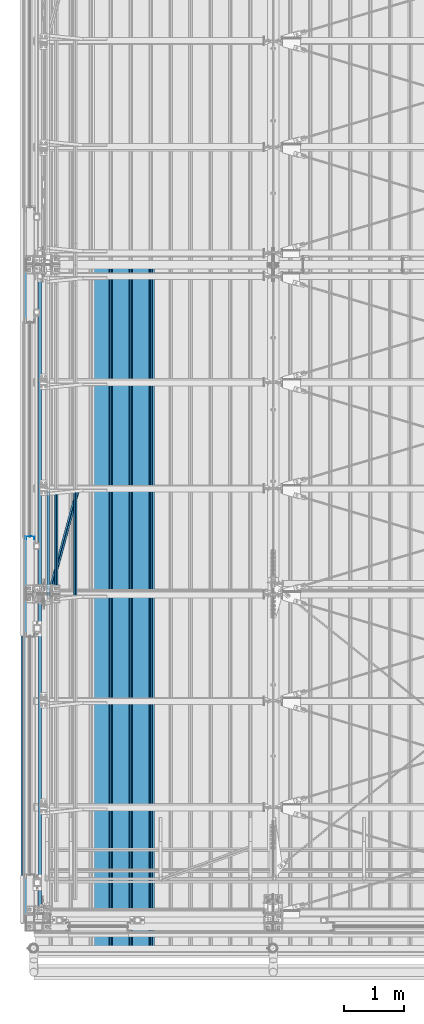
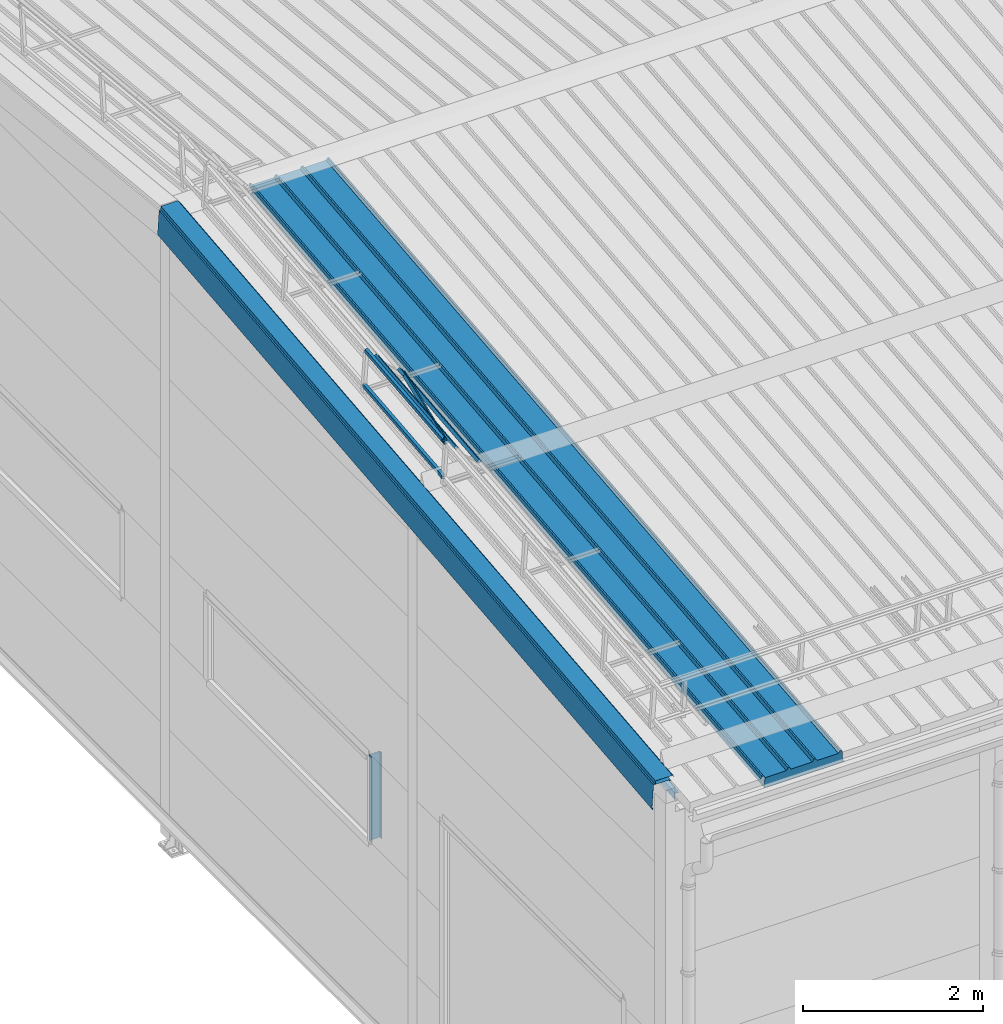
# One storey, part 33 of 709: 10 beams, 10 elements without a shape of their own.
"""IFC4 building model written with IfcOpenShell, lengths in millimetres."""

import ifcopenshell
import ifcopenshell.guid

model = None  # the IFC model being written
_history = None  # IfcOwnerHistory: only IFC2X3 demands one
_inside = {}  # id of a spatial element -> (the spatial element, [elements in it])
_under = {}  # id of a project, library or spatial element -> (it, [spatial elements below it])
_declared = {}  # id of a project -> (the project, [libraries it declares])
_typed = {}  # id of a type object -> (the type object, [elements of that type])
_made_of = {}  # id of a material, layer set ... -> (it, [elements and type objects made of it])


def new_model(schema):
    """Start an empty IFC model of exactly this schema.

    Asked for "IFC4X3", IfcOpenShell would pick the latest addendum, in which some entities
    have other attributes; the version numbers below select the first issue.
    IFC2X3 requires an IfcOwnerHistory on every rooted entity: one is made here for all.
    """
    global model, _history
    if schema == "IFC4X3":
        model = ifcopenshell.file(schema_version=(4, 3, 0, 0))
    else:
        model = ifcopenshell.file(schema=schema)
    _inside.clear()
    _under.clear()
    _declared.clear()
    _typed.clear()
    _made_of.clear()
    _history = None
    if model.schema == "IFC2X3":
        org = make("IfcOrganization", Name="unknown")
        user = make(
            "IfcPersonAndOrganization",
            ThePerson=make("IfcPerson", FamilyName="unknown"),
            TheOrganization=org,
        )
        app = make(
            "IfcApplication",
            ApplicationDeveloper=org,
            Version="unknown",
            ApplicationFullName="unknown",
            ApplicationIdentifier="unknown",
        )
        _history = make(
            "IfcOwnerHistory",
            OwningUser=user,
            OwningApplication=app,
            ChangeAction="ADDED",
            CreationDate=0,
        )
    return model


def make(cls, **values):
    """One entity of the class cls with the attributes given. An attribute that is None is left unset."""
    return model.create_entity(
        cls, **{name: value for name, value in values.items() if value is not None}
    )


def rooted(cls, **values):
    """An entity with a GlobalId (a new one), such as an element, a storey or a relation."""
    return make(cls, GlobalId=ifcopenshell.guid.new(), OwnerHistory=_history, **values)


def si_unit(unit_type, name, prefix=None):
    """IfcSIUnit, for example si_unit("LENGTHUNIT", "METRE", prefix="MILLI")."""
    return make("IfcSIUnit", UnitType=unit_type, Prefix=prefix, Name=name)


def assignment(units):
    """IfcUnitAssignment: the units of a project."""
    return None if units is None else make("IfcUnitAssignment", Units=units)


def point(xyz):
    """IfcCartesianPoint."""
    return None if xyz is None else make("IfcCartesianPoint", Coordinates=xyz)


def direction(xyz):
    """IfcDirection."""
    return None if xyz is None else make("IfcDirection", DirectionRatios=xyz)


def frame(location, z_axis=None, x_axis=None):
    """IfcAxis2Placement3D, a coordinate frame: its origin and axes. An axis left out is left unset."""
    return make(
        "IfcAxis2Placement3D",
        Location=point(location),
        Axis=direction(z_axis),
        RefDirection=direction(x_axis),
    )


def origin_with_axes():
    """The frame at (0, 0, 0) with the z axis (0, 0, 1) and the x axis (1, 0, 0) written out."""
    return frame((0.0, 0.0, 0.0), z_axis=(0.0, 0.0, 1.0), x_axis=(1.0, 0.0, 0.0))


def place(relative_to, where):
    """IfcLocalPlacement: puts the frame where relative to a parent placement (None: the world)."""
    return make(
        "IfcLocalPlacement", PlacementRelTo=relative_to, RelativePlacement=where
    )


def context(
    kind, dimensions, precision=None, world=None, true_north=None, identifier=None
):
    """IfcGeometricRepresentationContext, for example the 3D "Model" context."""
    return make(
        "IfcGeometricRepresentationContext",
        ContextIdentifier=identifier,
        ContextType=kind,
        CoordinateSpaceDimension=dimensions,
        Precision=precision,
        WorldCoordinateSystem=world,
        TrueNorth=true_north,
    )


def subcontext(parent, identifier, kind, view, scale=None):
    """IfcGeometricRepresentationSubContext, for example "Body" below "Model"."""
    return make(
        "IfcGeometricRepresentationSubContext",
        ContextIdentifier=identifier,
        ContextType=kind,
        ParentContext=parent,
        TargetScale=scale,
        TargetView=view,
    )


def project(units=None, contexts=None):
    """IfcProject with its units and contexts."""
    return rooted(
        "IfcProject",
        Name="project",
        RepresentationContexts=contexts,
        UnitsInContext=assignment(units),
    )


def spatial(cls, under=None, at=None, **own):
    """A site, building, storey or space (cls), placed at a placement, below another one or the project."""
    s = rooted(cls, ObjectPlacement=at, **own)
    if under is not None:
        _under.setdefault(under.id(), (under, []))[1].append(s)
    return s


def point_list(points):
    """IfcCartesianPointList2D or 3D."""
    cls = (
        "IfcCartesianPointList2D" if len(points[0]) == 2 else "IfcCartesianPointList3D"
    )
    return make(cls, CoordList=points)


def line(*indices):
    """IfcLineIndex: a straight run through numbered points of an indexed curve."""
    return model.create_entity("IfcLineIndex", indices)


def indexed_curve(points, segments=None, self_intersect=None):
    """IfcIndexedPolyCurve: lines and arcs through numbered points (the first is 1)."""
    return make(
        "IfcIndexedPolyCurve",
        Points=point_list(points),
        Segments=segments,
        SelfIntersect=self_intersect,
    )


def outline(outer, holes=None, kind="AREA"):
    """IfcArbitraryClosedProfileDef: a profile drawn as a closed curve; with holes, ...WithVoids."""
    if holes is None:
        return make("IfcArbitraryClosedProfileDef", ProfileType=kind, OuterCurve=outer)
    return make(
        "IfcArbitraryProfileDefWithVoids",
        ProfileType=kind,
        OuterCurve=outer,
        InnerCurves=holes,
    )


def extrude(swept, where, along, depth):
    """IfcExtrudedAreaSolid: the profile swept, set in the frame where, extruded along a direction by depth."""
    return make(
        "IfcExtrudedAreaSolid",
        SweptArea=swept,
        Position=where,
        ExtrudedDirection=direction(along),
        Depth=depth,
    )


def shape(context_of_items, identifier, shape_type, items):
    """IfcShapeRepresentation: the items that make up one representation, for example the "Body"."""
    return make(
        "IfcShapeRepresentation",
        ContextOfItems=context_of_items,
        RepresentationIdentifier=identifier,
        RepresentationType=shape_type,
        Items=items,
    )


def material(Name=None, Category=None):
    """IfcMaterial."""
    return make("IfcMaterial", Name=Name, Category=Category)


def made_of(thing, what):
    """Note that an element or type object is made of a material, layer set ...; save() writes the relation."""
    if what is not None:
        _made_of.setdefault(what.id(), (what, []))[1].append(thing)
    return thing


def element(
    cls,
    number,
    at=None,
    inside=None,
    cuts=None,
    type_object=None,
    material=None,
    context=None,
    identifier="Body",
    shape_type=None,
    held_by="IfcProductDefinitionShape",
    body=None,
    shapes=None,
    **own,
):
    """One element of the class cls, such as IfcWall. Its Tag is "e" and its number.

    at: its placement. inside: the storey or other place that contains it. cuts: it is an
    opening in that element (IfcRelVoidsElement). A single representation is given by context,
    identifier, shape_type and body (its items); several are given by shapes. held_by: the class
    of the entity that holds the representations. save() writes the other relations.
    """
    e = rooted(cls, Tag="e%d" % number, ObjectPlacement=at, **own)
    if body is not None:
        shapes = [shape(context, identifier, shape_type, body)]
    if shapes is not None:
        e.Representation = make(held_by, Representations=shapes)
    if inside is not None:
        _inside.setdefault(inside.id(), (inside, []))[1].append(e)
    if cuts is not None:
        rooted(
            "IfcRelVoidsElement", RelatingBuildingElement=cuts, RelatedOpeningElement=e
        )
    if type_object is not None:
        _typed.setdefault(type_object.id(), (type_object, []))[1].append(e)
    return made_of(e, material)


def aggregate(whole, parts):
    """IfcRelAggregates: a whole, such as a stair, and the parts it consists of."""
    return rooted("IfcRelAggregates", RelatingObject=whole, RelatedObjects=parts)


def save(model, path):
    """Write the relations noted so far, then the file.

    IfcRelAggregates (storeys below a building ...), IfcRelContainedInSpatialStructure (elements
    in a storey), IfcRelDefinesByType, IfcRelAssociatesMaterial and IfcRelDeclares: one each for
    every whole, place, type object, material and project.
    """
    for whole, parts in _under.values():
        aggregate(whole, parts)
    for where, things in _inside.values():
        rooted(
            "IfcRelContainedInSpatialStructure",
            RelatedElements=things,
            RelatingStructure=where,
        )
    for kind, things in _typed.values():
        rooted("IfcRelDefinesByType", RelatedObjects=things, RelatingType=kind)
    for what, things in _made_of.values():
        rooted("IfcRelAssociatesMaterial", RelatedObjects=things, RelatingMaterial=what)
    for by, libraries in _declared.values():
        rooted("IfcRelDeclares", RelatingContext=by, RelatedDefinitions=libraries)
    model.write(path)


model = new_model("IFC4")

# Units and contexts
model_context = context("Model", 3, precision=0.2, world=origin_with_axes(), true_north=direction((0.0, 1.0)))
body_context = subcontext(model_context, "Body", "Model", "MODEL_VIEW")
ifc_project = project(units=[si_unit("LENGTHUNIT", "METRE", prefix="MILLI"), si_unit("AREAUNIT", "SQUARE_METRE"), si_unit("VOLUMEUNIT", "CUBIC_METRE"), si_unit("MASSUNIT", "GRAM", prefix="KILO"), si_unit("TIMEUNIT", "SECOND"), si_unit("PLANEANGLEUNIT", "RADIAN"), si_unit("SOLIDANGLEUNIT", "STERADIAN"), si_unit("THERMODYNAMICTEMPERATUREUNIT", "DEGREE_CELSIUS"), si_unit("LUMINOUSINTENSITYUNIT", "LUMEN")], contexts=[model_context])

# Site, building, storey
site_placement = place(None, origin_with_axes())
site = spatial("IfcSite", under=ifc_project, at=site_placement, CompositionType="ELEMENT")
building_placement = place(site_placement, origin_with_axes())
building = spatial("IfcBuilding", under=site, at=building_placement, Name="Undefined", CompositionType="ELEMENT")
storey_placement = place(building_placement, origin_with_axes())
storey = spatial("IfcBuildingStorey", under=building, at=storey_placement, Name="Undefined", CompositionType="ELEMENT", Elevation=0.0)

# Assembly, beam
assembly_1_placement = place(storey_placement, frame((1452.44, -410.89541, 7279.78979), z_axis=(1.0, 0.0, 0.0), x_axis=(0.0, 0.9950371902, 0.099503719)))
assembly_1 = element("IfcElementAssembly", 1, at=assembly_1_placement, inside=storey)
ifc_material_1 = material(Name="Insulation", Category="Insulation")
beam_1_placement = place(assembly_1_placement, origin_with_axes())
beam_1 = element("IfcBeam", 2, at=beam_1_placement, material=ifc_material_1, ObjectType="P-99", context=body_context, shape_type="SolidModel", body=[
    extrude(outline(indexed_curve([(-509.8453, 89.5), (-490.1547, 89.5), (-471.67949, 57.5), (-471.67949, -88.5), (-436.67949, -88.5), (-436.67949, -91.5), (562.55841, -91.5), (562.55841, -89.5), (527.55841, -89.5), (527.55841, 57.5), (510.2379, 88.5), (489.7621, 88.5), (472.44159, 58.5), (196.71923, 58.5), (177.66667, 91.5), (155.66667, 91.5), (136.61411, 58.5), (-136.61411, 58.5), (-155.66667, 91.5), (-177.66667, 91.5), (-196.71923, 58.5), (-469.94744, 58.5), (-489.0, 91.5), (-511.0, 91.5), (-527.16581, 63.5), (-525.43376, 62.5)], segments=[line(1, 2, 3, 4, 5, 6, 7, 8, 9, 10, 11, 12, 13, 14, 15, 16, 17, 18, 19, 20, 21, 22, 23, 24, 25, 26, 1)])), frame((0.0, 0.0, 0.0), z_axis=(-1.0, 0.0, 0.0), x_axis=(0.0, 0.0, 1.0)), (0.0, 0.0, -1.0), 11459.0),
])
aggregate(assembly_1, [beam_1])

assembly_2_placement = place(storey_placement, frame((240.0, 5395.5211, 8622.71451), z_axis=(1.0, 0.0, 0.0), x_axis=(0.0, 0.9950371902, 0.099503719)))
assembly_2 = element("IfcElementAssembly", 3, at=assembly_2_placement, inside=storey)
ifc_material_2 = material(Name="Steel_Undefined", Category="STEEL")
beam_2_placement = place(assembly_2_placement, origin_with_axes())
beam_2 = element("IfcBeam", 4, at=beam_2_placement, material=ifc_material_2, ObjectType="610", context=body_context, shape_type="SolidModel", body=[
    extrude(outline(indexed_curve([(-20.0, -25.0), (20.0, -25.0), (20.0, -22.5), (-17.5, -22.5), (-17.5, 22.5), (20.0, 22.5), (20.0, 25.0), (-20.0, 25.0)], segments=[line(1, 2, 3, 4, 5, 6, 7, 8, 1)])), frame((0.0, 0.0, 0.0), z_axis=(-1.0, 0.0, 0.0), x_axis=(0.0, 0.0, 1.0)), (0.0, 0.0, -1.0), 1782.14469),
])
aggregate(assembly_2, [beam_2])

assembly_3_placement = place(storey_placement, frame((240.0, 5445.27295, 8125.19591), z_axis=(1.0, 0.0, 0.0), x_axis=(0.0, 0.9950371902, 0.099503719)))
assembly_3 = element("IfcElementAssembly", 5, at=assembly_3_placement, inside=storey)
beam_3_placement = place(assembly_3_placement, origin_with_axes())
beam_3 = element("IfcBeam", 6, at=beam_3_placement, material=ifc_material_2, ObjectType="610", context=body_context, shape_type="SolidModel", body=[
    extrude(outline(indexed_curve([(-20.0, -25.0), (20.0, -25.0), (20.0, -22.5), (-17.5, -22.5), (-17.5, 22.5), (20.0, 22.5), (20.0, 25.0), (-20.0, 25.0)], segments=[line(1, 2, 3, 4, 5, 6, 7, 8, 1)])), frame((0.0, 0.0, 0.0), z_axis=(-1.0, 0.0, 0.0), x_axis=(0.0, 0.0, 1.0)), (0.0, 0.0, -1.0), 1782.14469),
])
aggregate(assembly_3, [beam_3])

assembly_4_placement = place(storey_placement, frame((375.56349, 5408.18585, 8496.06695), z_axis=(0.7071067814, -0.0703597545, 0.7035975445), x_axis=(0.0, 0.9950371902, 0.099503719)))
assembly_4 = element("IfcElementAssembly", 7, at=assembly_4_placement, inside=storey)
beam_4_placement = place(assembly_4_placement, origin_with_axes())
beam_4 = element("IfcBeam", 8, at=beam_4_placement, material=ifc_material_2, ObjectType="610", context=body_context, shape_type="SolidModel", body=[
    extrude(outline(indexed_curve([(-20.0, -25.0), (20.0, -25.0), (20.0, -22.5), (-17.5, -22.5), (-17.5, 22.5), (20.0, 22.5), (20.0, 25.0), (-20.0, 25.0)], segments=[line(1, 2, 3, 4, 5, 6, 7, 8, 1)])), frame((0.0, 0.0, 0.0), z_axis=(-1.0, 0.0, 0.0), x_axis=(0.0, 0.0, 1.0)), (0.0, 0.0, -1.0), 1782.14469),
])
aggregate(assembly_4, [beam_4])

assembly_5_placement = place(storey_placement, frame((692.72078, 5439.74418, 8180.48365), z_axis=(0.7071067814, -0.0703597545, 0.7035975445), x_axis=(0.0, 0.9950371902, 0.099503719)))
assembly_5 = element("IfcElementAssembly", 9, at=assembly_5_placement, inside=storey)
beam_5_placement = place(assembly_5_placement, origin_with_axes())
beam_5 = element("IfcBeam", 10, at=beam_5_placement, material=ifc_material_2, ObjectType="610", context=body_context, shape_type="SolidModel", body=[
    extrude(outline(indexed_curve([(-20.0, -25.0), (20.0, -25.0), (20.0, -22.5), (-17.5, -22.5), (-17.5, 22.5), (20.0, 22.5), (20.0, 25.0), (-20.0, 25.0)], segments=[line(1, 2, 3, 4, 5, 6, 7, 8, 1)])), frame((0.0, 0.0, 0.0), z_axis=(-1.0, 0.0, 0.0), x_axis=(0.0, 0.0, 1.0)), (0.0, 0.0, -1.0), 1782.14469),
])
aggregate(assembly_5, [beam_5])

assembly_6_placement = place(storey_placement, frame((234.14214, 5394.1139, 8636.78646), z_axis=(0.7071067814, -0.0703597545, 0.7035975445), x_axis=(0.2585142339, 0.9518781635, -0.1646157729)))
assembly_6 = element("IfcElementAssembly", 11, at=assembly_6_placement, inside=storey)
beam_6_placement = place(assembly_6_placement, origin_with_axes())
beam_6 = element("IfcBeam", 12, at=beam_6_placement, material=ifc_material_2, ObjectType="612", context=body_context, shape_type="SolidModel", body=[
    extrude(outline(indexed_curve([(-20.0, -25.0), (20.0, -25.0), (20.0, -22.5), (-17.5, -22.5), (-17.5, 22.5), (20.0, 22.5), (20.0, 25.0), (-20.0, 25.0)], segments=[line(1, 2, 3, 4, 5, 6, 7, 8, 1)])), frame((0.0, 0.0, 0.0), z_axis=(-1.0, 0.0, 0.0), x_axis=(0.0, 0.0, 1.0)), (0.0, 0.0, -1.0), 1914.6905),
])
aggregate(assembly_6, [beam_6])

assembly_7_placement = place(storey_placement, frame((-60.0, 6440.0, 3870.0), z_axis=(1.0, 0.0, 0.0), x_axis=(0.0, 0.0, -1.0)))
assembly_7 = element("IfcElementAssembly", 13, at=assembly_7_placement, inside=storey)
beam_7_placement = place(assembly_7_placement, origin_with_axes())
beam_7 = element("IfcBeam", 14, at=beam_7_placement, material=ifc_material_2, context=body_context, shape_type="SolidModel", body=[
    extrude(outline(indexed_curve([(-70.0, -25.0), (-68.0, -25.0), (-68.0, 23.0), (68.0, 23.0), (68.0, -25.0), (70.0, -25.0), (70.0, 25.0), (-70.0, 25.0)], segments=[line(1, 2, 3, 4, 5, 6, 7, 8, 1)])), frame((0.0, 0.0, 0.0), z_axis=(-1.0, 0.0, 0.0), x_axis=(0.0, 0.0, 1.0)), (0.0, 0.0, -1.0), 1170.0),
])
aggregate(assembly_7, [beam_7])

assembly_8_placement = place(storey_placement, frame((-110.0, 11015.3709, 8363.62532), z_axis=(0.0, -0.102472673, 0.9947358199), x_axis=(0.0, -0.9947358198, -0.102472673)))
assembly_8 = element("IfcElementAssembly", 15, at=assembly_8_placement, inside=storey)
beam_8_placement = place(assembly_8_placement, origin_with_axes())
beam_8 = element("IfcBeam", 16, at=beam_8_placement, material=ifc_material_2, context=body_context, shape_type="SolidModel", body=[
    extrude(outline(indexed_curve([(-175.0, -100.0), (175.0, -100.0), (175.0, 100.0), (160.75, 100.0), (160.75, 124.25), (159.13, 124.25), (159.13, 104.25), (159.88, 104.25), (159.88, 123.5), (160.0, 123.5), (160.0, 99.25), (174.25, 99.25), (174.25, -99.25), (-174.25, -99.25), (-174.25, -85.0), (-198.5, -85.0), (-198.5, -84.88), (-179.25, -84.88), (-179.25, -84.13), (-199.25, -84.13), (-199.25, -85.75), (-175.0, -85.75)], segments=[line(1, 2, 3, 4, 5, 6, 7, 8, 9, 10, 11, 12, 13, 14, 15, 16, 17, 18, 19, 20, 21, 22, 1)])), frame((0.0, 0.0, 0.0), z_axis=(-1.0, 0.0, 0.0), x_axis=(0.0, 0.0, 1.0)), (0.0, 0.0, -1.0), 11058.21242),
])
aggregate(assembly_8, [beam_8])

assembly_9_placement = place(storey_placement, frame((-80.0, 10992.31455, 8587.44088), z_axis=(1.0, 0.0, 0.0), x_axis=(0.0, -0.9947358198, -0.102472673)))
assembly_9 = element("IfcElementAssembly", 17, at=assembly_9_placement, inside=storey)
beam_9_placement = place(assembly_9_placement, origin_with_axes())
beam_9 = element("IfcBeam", 18, at=beam_9_placement, material=ifc_material_2, context=body_context, shape_type="SolidModel", body=[
    extrude(outline(indexed_curve([(-110.0, -1.0), (110.0, -1.0), (131.2132, 20.2132), (129.79899, 21.62742), (109.17157, 1.0), (-108.0, 1.0), (-108.0, 49.0), (-110.0, 49.0)], segments=[line(1, 2, 3, 4, 5, 6, 7, 8, 1)])), frame((0.0, 0.0, 0.0), z_axis=(-1.0, 0.0, 0.0), x_axis=(0.0, 0.0, 1.0)), (0.0, 0.0, -1.0), 11058.21242),
])
aggregate(assembly_9, [beam_9])

assembly_10_placement = place(storey_placement, frame((80.0, 11025.61817, 8264.15174), z_axis=(0.0, -0.102472673, 0.9947358199), x_axis=(0.0, -0.9947358198, -0.102472673)))
assembly_10 = element("IfcElementAssembly", 19, at=assembly_10_placement, inside=storey)
beam_10_placement = place(assembly_10_placement, origin_with_axes())
beam_10 = element("IfcBeam", 20, at=beam_10_placement, material=ifc_material_2, context=body_context, shape_type="SolidModel", body=[
    extrude(outline(indexed_curve([(-45.0, -1.0), (45.0, -1.0), (45.0, 49.0), (43.0, 49.0), (43.0, 1.0), (-45.0, 1.0)], segments=[line(1, 2, 3, 4, 5, 6, 1)])), frame((0.0, 0.0, 0.0), z_axis=(-1.0, 0.0, 0.0), x_axis=(0.0, 0.0, 1.0)), (0.0, 0.0, -1.0), 11058.21242),
])
aggregate(assembly_10, [beam_10])

save(model, "model.ifc")
